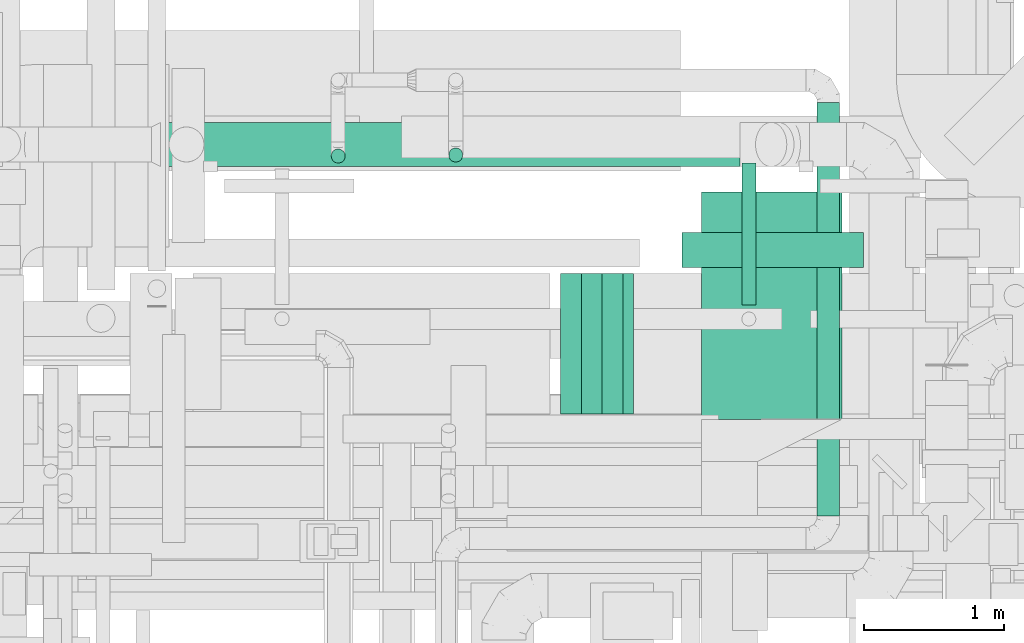
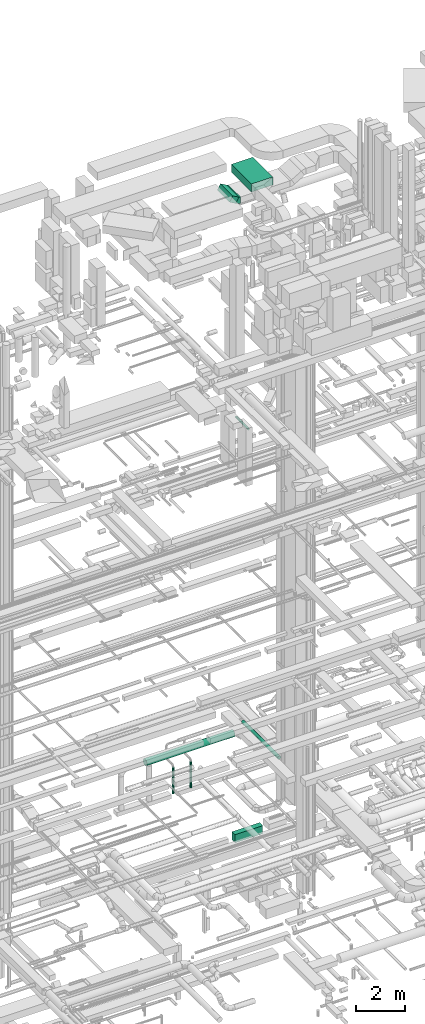
# One storey, part 73 of 337: 8 flow segments, 1 flow fitting.
"""IFC2X3 building model written with IfcOpenShell, lengths in millimetres."""

from ifc_helpers import new_model, entity, si_unit, converted_unit, derived_unit, direction, frame, frame_2d, origin, origin_2d_with_axis, place, context, subcontext, project, spatial, polyline, circle_curve, parameter, trimmed, segment, composite_curve, rectangle, circle, outline, extrude, source, transform, mapped, material, type_object, type_shapes, element, save


model = new_model("IFC2X3")

# Units and contexts
model_context = context("Model", 3, precision=0.01, world=origin(), true_north=direction((6.12303176911189e-17, 1.0)))
body_context = subcontext(model_context, "Body", "Model", "MODEL_VIEW")
ifc_project = project(units=[si_unit("LENGTHUNIT", "METRE", prefix="MILLI"), si_unit("AREAUNIT", "SQUARE_METRE"), si_unit("VOLUMEUNIT", "CUBIC_METRE"), converted_unit("PLANEANGLEUNIT", "DEGREE", entity("IfcRatioMeasure", 0.0174532925199433), si_unit("PLANEANGLEUNIT", "RADIAN"), dimensions=[0, 0, 0, 0, 0, 0, 0]), si_unit("MASSUNIT", "GRAM", prefix="KILO"), derived_unit("MASSDENSITYUNIT", [(si_unit("MASSUNIT", "GRAM", prefix="KILO"), 1), (si_unit("LENGTHUNIT", "METRE"), -3)]), derived_unit("MOMENTOFINERTIAUNIT", [(si_unit("LENGTHUNIT", "METRE"), 4)]), si_unit("TIMEUNIT", "SECOND"), si_unit("FREQUENCYUNIT", "HERTZ"), si_unit("THERMODYNAMICTEMPERATUREUNIT", "DEGREE_CELSIUS"), derived_unit("THERMALTRANSMITTANCEUNIT", [(si_unit("MASSUNIT", "GRAM", prefix="KILO"), 1), (si_unit("THERMODYNAMICTEMPERATUREUNIT", "KELVIN"), -1), (si_unit("TIMEUNIT", "SECOND"), -3)]), derived_unit("VOLUMETRICFLOWRATEUNIT", [(si_unit("LENGTHUNIT", "METRE"), 3), (si_unit("TIMEUNIT", "SECOND"), -1)]), derived_unit("MASSFLOWRATEUNIT", [(si_unit("MASSUNIT", "GRAM", prefix="KILO"), 1), (si_unit("TIMEUNIT", "SECOND"), -1)]), derived_unit("ROTATIONALFREQUENCYUNIT", [(si_unit("TIMEUNIT", "SECOND"), -1)]), si_unit("ELECTRICCURRENTUNIT", "AMPERE"), si_unit("ELECTRICVOLTAGEUNIT", "VOLT"), si_unit("POWERUNIT", "WATT"), si_unit("FORCEUNIT", "NEWTON", prefix="KILO"), si_unit("ILLUMINANCEUNIT", "LUX"), si_unit("LUMINOUSFLUXUNIT", "LUMEN"), si_unit("LUMINOUSINTENSITYUNIT", "CANDELA"), derived_unit("USERDEFINED", [(si_unit("MASSUNIT", "GRAM", prefix="KILO"), -1), (si_unit("LENGTHUNIT", "METRE"), -2), (si_unit("TIMEUNIT", "SECOND"), 3), (si_unit("LUMINOUSFLUXUNIT", "LUMEN"), 1)]), derived_unit("LINEARVELOCITYUNIT", [(si_unit("LENGTHUNIT", "METRE"), 1), (si_unit("TIMEUNIT", "SECOND"), -1)]), si_unit("PRESSUREUNIT", "PASCAL"), derived_unit("USERDEFINED", [(si_unit("LENGTHUNIT", "METRE"), -2), (si_unit("MASSUNIT", "GRAM", prefix="KILO"), 1), (si_unit("TIMEUNIT", "SECOND"), -2)]), derived_unit("LINEARFORCEUNIT", [(si_unit("MASSUNIT", "GRAM", prefix="KILO"), 1), (si_unit("LENGTHUNIT", "METRE"), 1), (si_unit("TIMEUNIT", "SECOND"), -2), (si_unit("LENGTHUNIT", "METRE"), -1)]), derived_unit("PLANARFORCEUNIT", [(si_unit("MASSUNIT", "GRAM", prefix="KILO"), 1), (si_unit("LENGTHUNIT", "METRE"), 1), (si_unit("TIMEUNIT", "SECOND"), -2), (si_unit("LENGTHUNIT", "METRE"), -2)])], contexts=[model_context])

# Site, building, storey
site_placement = place(None, origin())
site = spatial("IfcSite", under=ifc_project, at=site_placement, CompositionType="ELEMENT")
building_placement = place(site_placement, origin())
building = spatial("IfcBuilding", under=site, at=building_placement, CompositionType="ELEMENT")
storey_placement = place(building_placement, origin())
storey = spatial("IfcBuildingStorey", under=building, at=storey_placement, CompositionType="ELEMENT", Elevation=0.0)

# Flow segments
duct_segment_type_1 = type_object("IfcDuctSegmentType", PredefinedType="NOTDEFINED")
flow_segment_1_placement = place(storey_placement, frame((44883.53, 16499.25, -1325.0)))
element("IfcFlowSegment", 1, at=flow_segment_1_placement, inside=storey, type_object=duct_segment_type_1, context=body_context, shape_type="SweptSolid", body=[
    extrude(rectangle(XDim=1292.65842136534, YDim=249.999999999999, at=origin_2d_with_axis()), frame((646.33, 125.0, 0.0), z_axis=(0.0, 0.0, 1.0), x_axis=(-1.0, 0.0, 0.0)), (0.0, 0.0, 1.0), 400.0),
])
flow_segment_2_placement = place(storey_placement, frame((45022.31, 15417.27, 31500.0)))
element("IfcFlowSegment", 2, at=flow_segment_2_placement, inside=storey, type_object=duct_segment_type_1, context=body_context, shape_type="SweptSolid", body=[
    extrude(rectangle(XDim=1617.33384236178, YDim=999.999999999998, at=origin_2d_with_axis()), frame((500.0, 808.67, 0.0), z_axis=(0.0, 0.0, 1.0), x_axis=(0.0, -1.0, 0.0)), (0.0, 0.0, 1.0), 399.999999999996),
])
flow_segment_3_placement = place(storey_placement, frame((44019.92, 15454.64, 31160.29)))
element("IfcFlowSegment", 3, at=flow_segment_3_placement, inside=storey, type_object=duct_segment_type_1, context=body_context, shape_type="SweptSolid", body=[
    extrude(rectangle(XDim=299.999999999999, YDim=339.230500996708, at=frame_2d((0.0, 0.0), x_axis=(0.0, 1.0))), frame((221.89, 0.0, 214.71), z_axis=(0.0, 1.0, 0.0), x_axis=(0.866025410712626, 0.0, -0.499999988000027)), (0.0, 0.0, 1.0), 999.999999999998),
])
duct_segment_type_2 = type_object("IfcDuctSegmentType", PredefinedType="NOTDEFINED")
flow_segment_4_placement = place(storey_placement, frame((41171.92, 17215.18, 3276.72)))
element("IfcFlowSegment", 4, at=flow_segment_4_placement, inside=storey, type_object=duct_segment_type_2, context=body_context, shape_type="SweptSolid", body=[
    extrude(circle(Radius=157.5, at=origin_2d_with_axis()), frame((0.0, 159.1, 159.1), z_axis=(1.0, 0.0, 0.0), x_axis=(0.0, -1.0, 0.0)), (0.0, 0.0, 1.0), 4124.67196453104),
])
flow_segment_5_placement = place(storey_placement, frame((45845.05, 14728.87, 3518.4)))
element("IfcFlowSegment", 5, at=flow_segment_5_placement, inside=storey, type_object=duct_segment_type_2, context=body_context, shape_type="SweptSolid", body=[
    extrude(circle(Radius=80.0, at=origin_2d_with_axis()), frame((81.6, 0.0, 81.6), z_axis=(0.0, 1.0, 0.0), x_axis=(-1.0, 0.0, 0.0)), (0.0, 0.0, 1.0), 2943.09968702009),
])
flow_segment_6_placement = place(storey_placement, frame((45308.75, 16231.51, 19098.4)))
element("IfcFlowSegment", 6, at=flow_segment_6_placement, inside=storey, type_object=duct_segment_type_2, context=body_context, shape_type="SweptSolid", body=[
    extrude(circle(Radius=50.0, at=origin_2d_with_axis()), frame((51.6, 0.0, 51.6), z_axis=(0.0, 1.0, 0.0), x_axis=(1.0, 0.0, 0.0)), (0.0, 0.0, 1.0), 1011.95443527618),
])
flow_segment_7_placement = place(storey_placement, frame((43221.94, 17247.88, 1500.0)))
element("IfcFlowSegment", 7, at=flow_segment_7_placement, inside=storey, type_object=duct_segment_type_2, context=body_context, shape_type="SweptSolid", body=[
    extrude(circle(Radius=50.0, at=origin_2d_with_axis()), frame((51.6, 51.6, 0.0)), (0.0, 0.0, 1.0), 1284.99999999999),
])
flow_segment_8_placement = place(storey_placement, frame((42385.05, 17240.38, 1500.0)))
element("IfcFlowSegment", 8, at=flow_segment_8_placement, inside=storey, type_object=duct_segment_type_2, context=body_context, shape_type="SweptSolid", body=[
    extrude(circle(Radius=50.0, at=origin_2d_with_axis()), frame((51.6, 51.6, 0.0)), (0.0, 0.0, 1.0), 1300.00000000001),
])

# Flow fitting
ifc_material = material()
duct_fitting_type = type_object("IfcDuctFittingType", PredefinedType="NOTDEFINED", material=ifc_material)
shared_shape = source(origin(), body_context, "Body", "SweptSolid", [
    extrude(outline(composite_curve([segment(polyline([(-170.1, -75.0), (129.9, -75.0)]), True, "CONTINUOUS"), segment(trimmed(circle_curve(frame_2d((279.9, -75.0), x_axis=(-0.866025410712655, 0.499999987999976)), 150.0), [parameter(0.0)], [parameter(29.9999992060848)], True, "PARAMETER"), False, "CONTINUOUS"), segment(polyline([(150.0, 0.0), (-109.81, 150.0)]), True, "CONTINUOUS"), segment(trimmed(circle_curve(frame_2d((279.9, -75.0), x_axis=(-0.866025410712655, 0.499999987999976)), 450.0), [parameter(0.0)], [parameter(29.9999992060848)], True, "PARAMETER"), True, "CONTINUOUS")], self_intersect=False)), frame((-5.38, 20.1, -500.0), z_axis=(0.0, 0.0, 1.0), x_axis=(-0.499999987999976, 0.866025410712655, 0.0)), (0.0, 0.0, 1.0), 1000.0),
])
type_shapes(duct_fitting_type, [shared_shape])
flow_fitting_placement = place(storey_placement, frame((44458.31, 15954.64, 31250.0), z_axis=(0.0, -1.0, 0.0), x_axis=(0.866025410712626, 0.0, -0.499999988000027)))
element("IfcFlowFitting", 9, at=flow_fitting_placement, inside=storey, type_object=duct_fitting_type, material=ifc_material, context=body_context, shape_type="MappedRepresentation", body=[
    mapped(shared_shape, transform((0.0, 0.0, 0.0), scale=1.0)),
])

save(model, "model.ifc")
